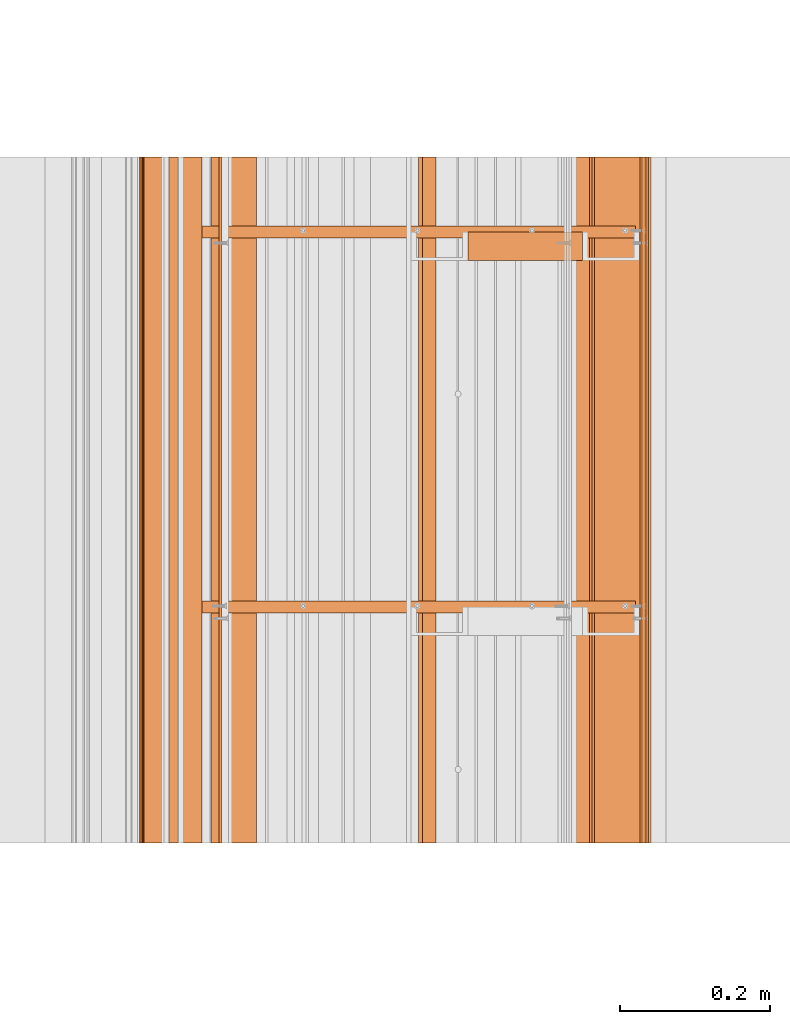
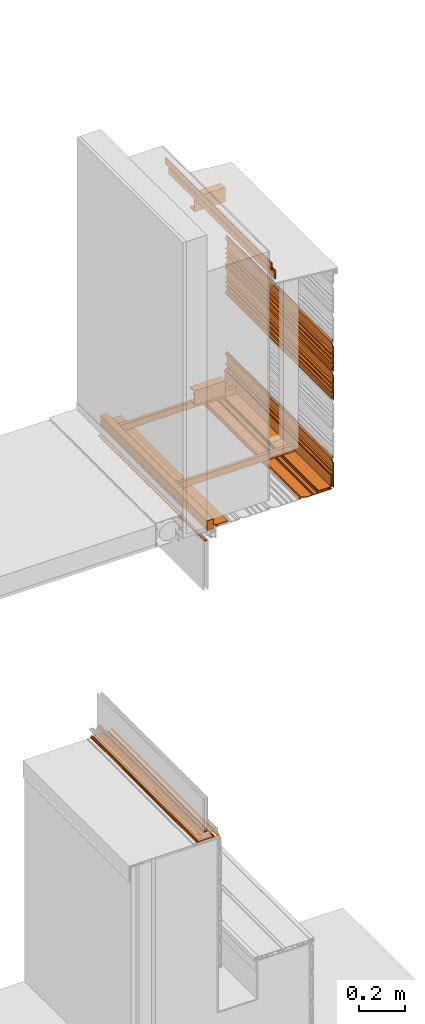
# One storey, part 6 of 36: 17 proxies.
"""IFC2X3 building model written with IfcOpenShell, lengths in feet."""

from ifc_helpers import new_model, entity, si_unit, converted_unit, derived_unit, direction, frame, frame_2d, origin, origin_2d_with_axis, place, context, subcontext, project, spatial, polyline, circle_curve, parameter, trimmed, segment, composite_curve, rectangle, outline, extrude, source, transform, mapped, material, type_object, type_shapes, element, save


model = new_model("IFC2X3")

# Units and contexts
model_context = context("Model", 3, precision=0.0001, world=origin(), true_north=direction((6.12303176911189e-17, 1.0)))
body_context = subcontext(model_context, "Body", "Model", "MODEL_VIEW")
ifc_project = project(units=[converted_unit("LENGTHUNIT", "FOOT", entity("IfcRatioMeasure", 0.3048), si_unit("LENGTHUNIT", "METRE"), dimensions=[1, 0, 0, 0, 0, 0, 0]), converted_unit("AREAUNIT", "SQUARE FOOT", entity("IfcRatioMeasure", 0.09290304), si_unit("AREAUNIT", "SQUARE_METRE"), dimensions=[2, 0, 0, 0, 0, 0, 0]), converted_unit("VOLUMEUNIT", "CUBIC FOOT", entity("IfcRatioMeasure", 0.028316846592), si_unit("VOLUMEUNIT", "CUBIC_METRE"), dimensions=[3, 0, 0, 0, 0, 0, 0]), converted_unit("PLANEANGLEUNIT", "DEGREE", entity("IfcRatioMeasure", 0.0174532925199433), si_unit("PLANEANGLEUNIT", "RADIAN"), dimensions=[0, 0, 0, 0, 0, 0, 0]), si_unit("MASSUNIT", "GRAM", prefix="KILO"), derived_unit("MASSDENSITYUNIT", [(si_unit("MASSUNIT", "GRAM", prefix="KILO"), 1), (si_unit("LENGTHUNIT", "METRE"), -3)]), si_unit("TIMEUNIT", "SECOND"), si_unit("FREQUENCYUNIT", "HERTZ"), si_unit("THERMODYNAMICTEMPERATUREUNIT", "DEGREE_CELSIUS"), derived_unit("THERMALTRANSMITTANCEUNIT", [(si_unit("MASSUNIT", "GRAM", prefix="KILO"), 1), (si_unit("THERMODYNAMICTEMPERATUREUNIT", "KELVIN"), -1), (si_unit("TIMEUNIT", "SECOND"), -3)]), derived_unit("VOLUMETRICFLOWRATEUNIT", [(si_unit("LENGTHUNIT", "METRE"), 3), (si_unit("TIMEUNIT", "SECOND"), -1)]), si_unit("ELECTRICCURRENTUNIT", "AMPERE"), si_unit("ELECTRICVOLTAGEUNIT", "VOLT"), si_unit("POWERUNIT", "WATT"), si_unit("FORCEUNIT", "NEWTON"), si_unit("ILLUMINANCEUNIT", "LUX"), si_unit("LUMINOUSFLUXUNIT", "LUMEN"), si_unit("LUMINOUSINTENSITYUNIT", "CANDELA"), derived_unit("USERDEFINED", [(si_unit("MASSUNIT", "GRAM", prefix="KILO"), -1), (si_unit("LENGTHUNIT", "METRE"), -2), (si_unit("TIMEUNIT", "SECOND"), 3), (si_unit("LUMINOUSFLUXUNIT", "LUMEN"), 1)]), derived_unit("LINEARVELOCITYUNIT", [(si_unit("LENGTHUNIT", "METRE"), 1), (si_unit("TIMEUNIT", "SECOND"), -1)]), si_unit("PRESSUREUNIT", "PASCAL"), derived_unit("USERDEFINED", [(si_unit("LENGTHUNIT", "METRE"), -2), (si_unit("MASSUNIT", "GRAM", prefix="KILO"), 1), (si_unit("TIMEUNIT", "SECOND"), -2)])], contexts=[model_context])

# Site, building, storey
site_placement = place(None, origin())
site = spatial("IfcSite", under=ifc_project, at=site_placement, CompositionType="ELEMENT")
building_placement = place(site_placement, origin())
building = spatial("IfcBuilding", under=site, at=building_placement, CompositionType="ELEMENT")
storey_placement = place(building_placement, origin())
storey = spatial("IfcBuildingStorey", under=building, at=storey_placement, Name="Level 1", CompositionType="ELEMENT", Elevation=0.0)

# Proxies
ifc_material_1 = material(Name="Window frame")
building_element_proxy_type_1 = type_object("IfcBuildingElementProxyType", Name="Window frame 094", PredefinedType="NOTDEFINED", material=ifc_material_1)
shared_shape_1 = source(origin(), body_context, "Body", "SweptSolid", [
    extrude(rectangle(XDim=3.0, YDim=0.0416666666666714, at=frame_2d((0.0, -7.105427357601e-15), x_axis=(1.0, 0.0))), frame((123.357415434482, -62.7284331589239, 4.52075), z_axis=(0.0, 0.0, 1.0), x_axis=(0.0, 1.0, 0.0)), (0.0, 0.0, 1.0), 0.0208333333333339),
])
type_shapes(building_element_proxy_type_1, [shared_shape_1])
proxy_1_placement = place(storey_placement, origin())
element("IfcBuildingElementProxy", 1, at=proxy_1_placement, inside=storey, type_object=building_element_proxy_type_1, material=ifc_material_1, Name="Window frame 094:Window frame 094", ObjectType="Window frame 094", context=body_context, shape_type="MappedRepresentation", body=[
    mapped(shared_shape_1, transform((0.0, 0.0, 0.0), scale=1.0)),
])
building_element_proxy_type_2 = type_object("IfcBuildingElementProxyType", Name="Window frame 095", PredefinedType="NOTDEFINED", material=ifc_material_1)
shared_shape_2 = source(origin(), body_context, "Body", "SweptSolid", [
    extrude(outline(composite_curve([segment(polyline([(-0.00744351318149761, 0.135335823128543), (-0.00744351318149761, 0.149502489795225)]), True, "CONTINUOUS"), segment(polyline([(-0.00744351318149761, 0.149502489795225), (-0.0141101798481644, 0.149502489795225)]), True, "CONTINUOUS"), segment(polyline([(-0.0141101798481644, 0.149502489795225), (-0.0141101798481644, -0.149660010204755)]), True, "CONTINUOUS"), segment(polyline([(-0.0141101798481644, -0.149660010204755), (-0.00744351318149761, -0.149660010204755)]), True, "CONTINUOUS"), segment(polyline([(-0.00744351318149761, -0.149660010204755), (-0.00744351318149761, -0.135493343538101)]), True, "CONTINUOUS"), segment(polyline([(-0.00744351318149761, -0.135493343538101), (-0.000276846514831064, -0.135493343538101)]), True, "CONTINUOUS"), segment(polyline([(-0.000276846514831064, -0.135493343538101), (-0.000276846514831064, -0.140660010204769)]), True, "CONTINUOUS"), segment(polyline([(-0.000276846514829288, -0.140660010204769), (0.0178066927118987, -0.134076601914842)]), True, "CONTINUOUS"), segment(trimmed(circle_curve(frame_2d((0.0168087855685712, -0.131335515204697), x_axis=(0.0, -1.0)), 0.00291708331506905), [parameter(20.0043036276874)], [parameter(200.000000499922)], True, "PARAMETER"), True, "CONTINUOUS"), segment(polyline([(0.0158110842911388, -0.12859435354801), (0.00647775095114334, -0.131969353550417)]), True, "CONTINUOUS"), segment(trimmed(circle_curve(frame_2d((0.00590771723513317, -0.13040319895471), x_axis=(0.0, -1.0)), 0.00166666692984399), [parameter(290.000003213652)], [parameter(20.0000019237645)], True, "PARAMETER"), False, "CONTINUOUS"), segment(polyline([(0.00434156265182217, -0.130973232704775), (-0.00744351318149761, -0.129660010204788)]), True, "CONTINUOUS"), segment(polyline([(-0.00744351318149761, -0.129660010204788), (-0.00744351318149761, -0.100826676871449)]), True, "CONTINUOUS"), segment(polyline([(-0.00744351318149761, -0.100826676871449), (-0.00744351318149761, 0.102314989795218)]), True, "CONTINUOUS"), segment(polyline([(-0.00744351318149761, 0.102314989795218), (-0.00744351318149761, 0.129502489795229)]), True, "CONTINUOUS"), segment(polyline([(-0.00744351318149761, 0.129502489795229), (0.00434156265178487, 0.130853212295236)]), True, "CONTINUOUS"), segment(trimmed(circle_curve(frame_2d((0.00590771723513317, 0.13028317854527), x_axis=(0.0, -1.0)), 0.00166666692984399), [parameter(159.938889813802)], [parameter(249.999996789979)], True, "PARAMETER"), False, "CONTINUOUS"), segment(polyline([(0.00647942099253029, 0.131848724286797), (0.0158110842425963, 0.128440999822942)]), True, "CONTINUOUS"), segment(trimmed(circle_curve(frame_2d((0.0168087855685712, 0.13118216146195), x_axis=(0.0, -1.0)), 0.00291708331506899), [parameter(339.999998588987)], [parameter(159.995696372378)], True, "PARAMETER"), True, "CONTINUOUS"), segment(polyline([(0.0178066927146974, 0.133923248179798), (-0.000276846514831064, 0.140506656461895)]), True, "CONTINUOUS"), segment(polyline([(-0.000276846514831064, 0.140506656461895), (-0.000276846514831064, 0.135335823128543)]), True, "CONTINUOUS"), segment(polyline([(-0.000276846514831064, 0.135335823128543), (-0.00744351318149761, 0.135335823128543)]), True, "CONTINUOUS")], self_intersect=False)), frame((123.357298205943, -64.2284331589239, 4.39944351318149), z_axis=(0.0, -1.0, 0.0), x_axis=(0.0, 0.0, 1.0)), (0.0, 0.0, -1.0), 3.0),
])
type_shapes(building_element_proxy_type_2, [shared_shape_2])
proxy_2_placement = place(storey_placement, origin())
element("IfcBuildingElementProxy", 2, at=proxy_2_placement, inside=storey, type_object=building_element_proxy_type_2, material=ifc_material_1, Name="Window frame 095:Window frame 095", ObjectType="Window frame 095", context=body_context, shape_type="MappedRepresentation", body=[
    mapped(shared_shape_2, transform((0.0, 0.0, 0.0), scale=1.0)),
])
ifc_material_2 = material()
building_element_proxy_type_3 = type_object("IfcBuildingElementProxyType", Name="Sealant 011", PredefinedType="NOTDEFINED", material=ifc_material_2)
shared_shape_3 = source(origin(), body_context, "Body", "SweptSolid", [
    extrude(outline(composite_curve([segment(polyline([(-0.00694444444445678, -0.00347222222222202), (0.00347222222222883, -0.00347222222222202)]), True, "CONTINUOUS"), segment(polyline([(0.00347222222222883, -0.00347222222222202), (0.00347222222221374, 0.00694444444444583)]), True, "CONTINUOUS"), segment(trimmed(circle_curve(frame_2d((-0.00694444444445767, 0.00694444444444583), x_axis=(-1.0, 0.0)), 0.0104166666666667), [parameter(90.0000000000001)], [parameter(179.999999999995)], True, "PARAMETER"), False, "CONTINUOUS")], self_intersect=False)), frame((123.561412114598, -64.2284331589239, 4.39917691716974), z_axis=(0.0, 1.0, 0.0), x_axis=(-1.0, 0.0, 0.0)), (0.0, 0.0, 1.0), 3.0),
])
type_shapes(building_element_proxy_type_3, [shared_shape_3])
proxy_3_placement = place(storey_placement, origin())
element("IfcBuildingElementProxy", 3, at=proxy_3_placement, inside=storey, type_object=building_element_proxy_type_3, material=ifc_material_2, Name="Sealant 011:Sealant 011", ObjectType="Sealant 011", context=body_context, shape_type="MappedRepresentation", body=[
    mapped(shared_shape_3, transform((0.0, 0.0, 0.0), scale=1.0)),
])
building_element_proxy_type_4 = type_object("IfcBuildingElementProxyType", Name="Window frame part 097", PredefinedType="NOTDEFINED", material=ifc_material_1)
shared_shape_4 = source(origin(), body_context, "Body", "SweptSolid", [
    extrude(rectangle(XDim=3.0, YDim=0.0416666666666572, at=origin_2d_with_axis()), frame((123.359415433694, -62.7284331589239, 9.53125000001312), z_axis=(0.0, 0.0, 1.0), x_axis=(0.0, 1.0, 0.0)), (0.0, 0.0, 1.0), 0.0208333333333321),
])
type_shapes(building_element_proxy_type_4, [shared_shape_4])
proxy_4_placement = place(storey_placement, origin())
element("IfcBuildingElementProxy", 4, at=proxy_4_placement, inside=storey, type_object=building_element_proxy_type_4, material=ifc_material_1, Name="Window frame part 097:Window frame part 097", ObjectType="Window frame part 097", context=body_context, shape_type="MappedRepresentation", body=[
    mapped(shared_shape_4, transform((0.0, 0.0, 0.0), scale=1.0)),
])
ifc_material_3 = material(Name="_EXISTING CAST-IN-PLACE CONCRETE")
building_element_proxy_type_5 = type_object("IfcBuildingElementProxyType", Name="starter strip 018", PredefinedType="NOTDEFINED", material=ifc_material_3)
shared_shape_5 = source(origin(), body_context, "Body", "SweptSolid", [
    extrude(outline(polyline([(-0.0613594857283317, -0.0154211442749244), (-0.0251609571194251, -0.0154211442749244), (-0.0251609571194251, -0.00592609112533005), (-0.0504897785761216, -0.00592609112533005), (-0.0504897785761216, 0.0053841388615421), (0.137010221423907, 0.0053841388615421), (0.137010221423907, 0.0159630965387141), (-0.0613594857283317, 0.0159630965387141), (-0.0613594857283317, -0.0154211442749244)])), frame((125.338156285059, -64.2284331589239, 9.74081747039039), z_axis=(0.0, 1.0, 0.0), x_axis=(-1.0, 0.0, 0.0)), (0.0, 0.0, 1.0), 3.0),
])
type_shapes(building_element_proxy_type_5, [shared_shape_5])
proxy_5_placement = place(storey_placement, origin())
element("IfcBuildingElementProxy", 5, at=proxy_5_placement, inside=storey, type_object=building_element_proxy_type_5, material=ifc_material_3, Name="starter strip 018:starter strip 018", ObjectType="starter strip 018", context=body_context, shape_type="MappedRepresentation", body=[
    mapped(shared_shape_5, transform((0.0, 0.0, 0.0), scale=1.0)),
])
building_element_proxy_type_6 = type_object("IfcBuildingElementProxyType", Name="Flashing 005", PredefinedType="NOTDEFINED", material=ifc_material_3)
shared_shape_6 = source(origin(), body_context, "Body", "SweptSolid", [
    extrude(outline(polyline([(0.013667551313393, -0.0378577431199574), (0.159773698392035, -0.0378577431199574), (0.159773698392035, -0.0199414287766899), (0.0215603079392768, -0.0199414287766899), (-0.0313095939307999, 0.0378577431393126), (-0.14213165577463, 0.0378577431393126), (-0.14213165577463, 0.0199414287572921), (-0.0392023505566836, 0.0199414287572921), (0.013667551313393, -0.0378577431199574)])), frame((124.468231916026, -64.2284331589239, 13.807758480938), z_axis=(0.0, 1.0, 0.0), x_axis=(0.0, 0.0, -1.0)), (0.0, 0.0, 1.0), 3.0),
])
type_shapes(building_element_proxy_type_6, [shared_shape_6])
proxy_6_placement = place(storey_placement, origin())
element("IfcBuildingElementProxy", 6, at=proxy_6_placement, inside=storey, type_object=building_element_proxy_type_6, material=ifc_material_3, Name="Flashing 005:Flashing 005", ObjectType="Flashing 005", context=body_context, shape_type="MappedRepresentation", body=[
    mapped(shared_shape_6, transform((0.0, 0.0, 0.0), scale=1.0)),
])
building_element_proxy_type_7 = type_object("IfcBuildingElementProxyType", Name="starter strip 019", PredefinedType="NOTDEFINED", material=ifc_material_3)
shared_shape_7 = source(origin(), body_context, "Body", "SweptSolid", [
    extrude(outline(polyline([(-0.0504897786253338, 0.00592609117455645), (-0.0251609571030116, 0.00592609117455645), (-0.0251609571030116, 0.015421144422568), (-0.0613594856463209, 0.015421144422568), (-0.0613594856463209, -0.0159630966207356), (0.137010221374666, -0.0159630966207356), (0.137010221374666, -0.00538413897637824), (-0.0504897786253338, -0.00538413897637824), (-0.0504897786253338, 0.00592609117455645)])), frame((123.583477418704, -64.2284331589239, 9.7408174703082), z_axis=(0.0, 1.0, 0.0), x_axis=(1.0, 0.0, 0.0)), (0.0, 0.0, 1.0), 3.0),
])
type_shapes(building_element_proxy_type_7, [shared_shape_7])
proxy_7_placement = place(storey_placement, origin())
element("IfcBuildingElementProxy", 7, at=proxy_7_placement, inside=storey, type_object=building_element_proxy_type_7, material=ifc_material_3, Name="starter strip 019:starter strip 019", ObjectType="starter strip 019", context=body_context, shape_type="MappedRepresentation", body=[
    mapped(shared_shape_7, transform((0.0, 0.0, 0.0), scale=1.0)),
])
building_element_proxy_type_8 = type_object("IfcBuildingElementProxyType", Name="Metal support for window frame003", PredefinedType="NOTDEFINED", material=ifc_material_3)
shared_shape_8 = source(origin(), body_context, "Body", "SweptSolid", [
    extrude(rectangle(XDim=3.0, YDim=0.107278015091865, at=frame_2d((0.0, 7.105427357601e-15), x_axis=(1.0, 0.0))), frame((123.430507377612, -62.7284331589239, 9.70833333333333), z_axis=(0.0, 0.0, 1.0), x_axis=(0.0, 1.0, 0.0)), (0.0, 0.0, 1.0), 0.166666666666668),
])
type_shapes(building_element_proxy_type_8, [shared_shape_8])
proxy_8_placement = place(storey_placement, origin())
element("IfcBuildingElementProxy", 8, at=proxy_8_placement, inside=storey, type_object=building_element_proxy_type_8, material=ifc_material_3, ObjectType="Metal support for window frame003", context=body_context, shape_type="MappedRepresentation", body=[
    mapped(shared_shape_8, transform((0.0, 0.0, 0.0), scale=1.0)),
])
building_element_proxy_type_9 = type_object("IfcBuildingElementProxyType", Name="panel 058", PredefinedType="NOTDEFINED", material=ifc_material_3)
shared_shape_9 = source(origin(), body_context, "Body", "SweptSolid", [
    extrude(outline(polyline([(-0.145680147068468, -0.0220175316852362), (0.291819852931525, -0.0220175316852362), (0.291819852931525, -0.0116008650185648), (0.237132352931535, -0.0116008650185648), (0.237132352931535, 0.00451787028327999), (0.257965686264864, 0.00451787028327999), (0.257965686264864, 0.0173047730391858), (0.22671568626486, 0.0173047730391858), (0.22671568626486, -0.0116008650185648), (0.143382352931521, -0.0116008650185648), (0.143382352931521, 0.0196491349814352), (0.132965686264869, 0.0196491349814352), (0.132965686264869, -0.0116008650185648), (0.060049019598182, -0.0116008650185648), (0.060049019598182, 0.0196491349814352), (0.0496323529315319, 0.0196491349814352), (0.0496323529315319, -0.0116008650185648), (-0.0232843137351324, -0.0116008650185648), (-0.0232843137351324, 0.0196491349814352), (-0.0337009804018074, 0.0196491349814352), (-0.0337009804018074, -0.0116008650185648), (-0.135263480401816, -0.0116008650185648), (-0.135263480401816, -0.00118419835187922), (-0.180710665113098, -0.00118419835187922), (-0.18994960080863, 0.0186287630982349), (-0.215994026661651, 0.0186287630982349), (-0.225232962029096, -0.00118419835187922), (-0.249846813735136, -0.00118419835187922), (-0.249846813735136, -0.0116008650185648), (-0.218596813735132, -0.0116008650185648), (-0.210299318000233, 0.00619317215335968), (-0.195644309470049, 0.00619317215335968), (-0.18734681373515, -0.0116008650185648), (-0.145680147068468, -0.0116008650185648), (-0.145680147068468, -0.0220175316852362)])), frame((125.424633043827, -64.2284331589239, 10.021009163627), z_axis=(0.0, 1.0, 0.0), x_axis=(0.0, 0.0, -1.0)), (0.0, 0.0, 1.0), 3.0),
])
type_shapes(building_element_proxy_type_9, [shared_shape_9])
proxy_9_placement = place(storey_placement, origin())
element("IfcBuildingElementProxy", 9, at=proxy_9_placement, inside=storey, type_object=building_element_proxy_type_9, material=ifc_material_3, Name="panel 058:panel 058", ObjectType="panel 058", context=body_context, shape_type="MappedRepresentation", body=[
    mapped(shared_shape_9, transform((0.0, 0.0, 0.0), scale=1.0)),
])
building_element_proxy_type_10 = type_object("IfcBuildingElementProxyType", Name="panel 059", PredefinedType="NOTDEFINED", material=ifc_material_3)
shared_shape_10 = source(origin(), body_context, "Body", "SweptSolid", [
    extrude(outline(polyline([(-0.145680147068472, -0.0220175316852362), (0.291819852931523, -0.0220175316852362), (0.291819852931523, -0.0116008650185648), (0.237132352931534, -0.0116008650185648), (0.237132352931534, 0.00451787028327999), (0.25796568626486, 0.00451787028327999), (0.25796568626486, 0.0173047730391858), (0.226715686264857, 0.0173047730391858), (0.226715686264857, -0.0116008650185648), (0.143382352931518, -0.0116008650185648), (0.143382352931518, 0.0196491349814352), (0.132965686264866, 0.0196491349814352), (0.132965686264866, -0.0116008650185648), (0.0600490195981802, -0.0116008650185648), (0.0600490195981802, 0.0196491349814352), (0.0496323529315283, 0.0196491349814352), (0.0496323529315283, -0.0116008650185648), (-0.0232843137351342, -0.0116008650185648), (-0.0232843137351342, 0.0196491349814352), (-0.0337009804018109, 0.0196491349814352), (-0.0337009804018109, -0.0116008650185648), (-0.13526348040182, -0.0116008650185648), (-0.13526348040182, -0.00118419835187922), (-0.180710665113102, -0.00118419835187922), (-0.189949600808633, 0.0186287630982349), (-0.215994026661654, 0.0186287630982349), (-0.2252329620291, -0.00118419835187922), (-0.24984681373514, -0.00118419835187922), (-0.24984681373514, -0.0116008650185648), (-0.218596813735134, -0.0116008650185648), (-0.210299318000237, 0.00619317215335968), (-0.195644309470051, 0.00619317215335968), (-0.187346813735154, -0.0116008650185648), (-0.145680147068472, -0.0116008650185648), (-0.145680147068472, -0.0220175316852362)])), frame((125.424633043827, -64.2284331589239, 11.521009163627), z_axis=(0.0, 1.0, 0.0), x_axis=(0.0, 0.0, -1.0)), (0.0, 0.0, 1.0), 3.0),
])
type_shapes(building_element_proxy_type_10, [shared_shape_10])
proxy_10_placement = place(storey_placement, origin())
element("IfcBuildingElementProxy", 10, at=proxy_10_placement, inside=storey, type_object=building_element_proxy_type_10, material=ifc_material_3, Name="panel 059:panel 059", ObjectType="panel 059", context=body_context, shape_type="MappedRepresentation", body=[
    mapped(shared_shape_10, transform((0.0, 0.0, 0.0), scale=1.0)),
])
building_element_proxy_type_11 = type_object("IfcBuildingElementProxyType", Name="starter strip 020", PredefinedType="NOTDEFINED", material=ifc_material_3)
shared_shape_11 = source(origin(), body_context, "Body", "SweptSolid", [
    extrude(outline(polyline([(-0.050489778625332, 0.00592609117455822), (-0.0251609571030116, 0.00592609117455822), (-0.0251609571030116, 0.0154211444225609), (-0.0613594856463298, 0.0154211444225609), (-0.0613594856463298, -0.0159630966207374), (0.137010221374673, -0.0159630966207374), (0.137010221374673, -0.00538413897638179), (-0.050489778625332, -0.00538413897638179), (-0.050489778625332, 0.00592609117455822)])), frame((125.415604431089, -64.2284331589239, 9.81008004634182), z_axis=(0.0, 1.0, 0.0), x_axis=(0.0, 0.0, 1.0)), (0.0, 0.0, 1.0), 3.0),
])
type_shapes(building_element_proxy_type_11, [shared_shape_11])
proxy_11_placement = place(storey_placement, origin())
element("IfcBuildingElementProxy", 11, at=proxy_11_placement, inside=storey, type_object=building_element_proxy_type_11, material=ifc_material_3, Name="starter strip 020:starter strip 020", ObjectType="starter strip 020", context=body_context, shape_type="MappedRepresentation", body=[
    mapped(shared_shape_11, transform((0.0, 0.0, 0.0), scale=1.0)),
])
building_element_proxy_type_12 = type_object("IfcBuildingElementProxyType", Name="panel 060", PredefinedType="NOTDEFINED", material=ifc_material_3)
shared_shape_12 = source(origin(), body_context, "Body", "SweptSolid", [
    extrude(outline(polyline([(0.0116008650030874, -0.29181985294116), (0.0220175316697411, -0.29181985294116), (0.0220175316697411, 0.145680147058869), (0.0116008650030874, 0.145680147058869), (0.0116008650030874, 0.187346813725526), (-0.00619317207042336, 0.195644309526045), (-0.00619317207042336, 0.210299317925006), (0.0116008650030874, 0.218596813725526), (0.0116008650030874, 0.24984681372554), (0.0011841983364107, 0.24984681372554), (0.0011841983364107, 0.22523296228195), (-0.0186287629496711, 0.215994026619228), (-0.0186287629496711, 0.189949600831824), (0.0011841983364107, 0.180710665169102), (0.0011841983364107, 0.135263480392183), (0.0116008650030874, 0.135263480392183), (0.0116008650030874, 0.0337009803921688), (-0.0196491349969179, 0.0337009803921688), (-0.0196491349969179, 0.0232843137255401), (0.0116008650030874, 0.0232843137255401), (0.0116008650030874, -0.0496323529411313), (-0.0196491349969179, -0.0496323529411313), (-0.0196491349969179, -0.0600490196078169), (0.0116008650030874, -0.0600490196078169), (0.0116008650030874, -0.132965686274474), (-0.0196491349969179, -0.132965686274474), (-0.0196491349969179, -0.143382352941146), (0.0116008650030874, -0.143382352941146), (0.0116008650030874, -0.226715686274488), (-0.0173047731202853, -0.226715686274488), (-0.0173047731202853, -0.257965686274474), (-0.00451787023313521, -0.257965686274474), (-0.00451787023313521, -0.237132352941131), (0.0116008650030874, -0.237132352941131), (0.0116008650030874, -0.29181985294116)])), frame((125.128789055904, -64.2284331589239, 9.73037350903193), z_axis=(0.0, 1.0, 0.0), x_axis=(0.0, 0.0, -1.0)), (0.0, 0.0, 1.0), 3.0),
])
type_shapes(building_element_proxy_type_12, [shared_shape_12])
proxy_12_placement = place(storey_placement, origin())
element("IfcBuildingElementProxy", 12, at=proxy_12_placement, inside=storey, type_object=building_element_proxy_type_12, material=ifc_material_3, Name="panel 060:panel 060", ObjectType="panel 060", context=body_context, shape_type="MappedRepresentation", body=[
    mapped(shared_shape_12, transform((0.0, 0.0, 0.0), scale=1.0)),
])
building_element_proxy_type_13 = type_object("IfcBuildingElementProxyType", Name="panel 061", PredefinedType="NOTDEFINED", material=ifc_material_3)
shared_shape_13 = source(origin(), body_context, "Body", "SweptSolid", [
    extrude(outline(polyline([(-0.145680147068472, -0.0220175316852362), (0.291819852931523, -0.0220175316852362), (0.291819852931523, -0.0116008650185648), (0.237132352931532, -0.0116008650185648), (0.237132352931532, 0.00451787028327999), (0.25796568626486, 0.00451787028327999), (0.25796568626486, 0.0173047730391858), (0.226715686264857, 0.0173047730391858), (0.226715686264857, -0.0116008650185648), (0.143382352931518, -0.0116008650185648), (0.143382352931518, 0.0196491349814352), (0.132965686264866, 0.0196491349814352), (0.132965686264866, -0.0116008650185648), (0.0600490195981784, -0.0116008650185648), (0.0600490195981784, 0.0196491349814352), (0.0496323529315283, 0.0196491349814352), (0.0496323529315283, -0.0116008650185648), (-0.0232843137351342, -0.0116008650185648), (-0.0232843137351342, 0.0196491349814352), (-0.0337009804018109, 0.0196491349814352), (-0.0337009804018109, -0.0116008650185648), (-0.13526348040182, -0.0116008650185648), (-0.13526348040182, -0.00118419835187922), (-0.180710665113102, -0.00118419835187922), (-0.189949600808633, 0.0186287630982349), (-0.215994026661654, 0.0186287630982349), (-0.2252329620291, -0.00118419835187922), (-0.24984681373514, -0.00118419835187922), (-0.24984681373514, -0.0116008650185648), (-0.218596813735134, -0.0116008650185648), (-0.210299318000237, 0.00619317215335968), (-0.195644309470053, 0.00619317215335968), (-0.187346813735154, -0.0116008650185648), (-0.145680147068472, -0.0116008650185648), (-0.145680147068472, -0.0220175316852362)])), frame((125.424633043827, -64.2284331589239, 12.021009163627), z_axis=(0.0, 1.0, 0.0), x_axis=(0.0, 0.0, -1.0)), (0.0, 0.0, 1.0), 3.0),
])
type_shapes(building_element_proxy_type_13, [shared_shape_13])
proxy_13_placement = place(storey_placement, origin())
element("IfcBuildingElementProxy", 13, at=proxy_13_placement, inside=storey, type_object=building_element_proxy_type_13, material=ifc_material_3, Name="panel 061:panel 061", ObjectType="panel 061", context=body_context, shape_type="MappedRepresentation", body=[
    mapped(shared_shape_13, transform((0.0, 0.0, 0.0), scale=1.0)),
])
building_element_proxy_type_14 = type_object("IfcBuildingElementProxyType", Name="Stud 007", PredefinedType="NOTDEFINED", material=ifc_material_3)
shared_shape_14 = source(origin(), body_context, "Body", "SweptSolid", [
    extrude(outline(polyline([(-0.0286458333333286, -0.0572916666666679), (0.0234375000000071, -0.0572916666666679), (0.0234375000000071, -0.046875), (-0.0182291666666572, -0.046875), (-0.0182291666666572, 0.046875), (0.0234375000000071, 0.046875), (0.0234375000000071, 0.0572916666666661), (-0.0286458333333286, 0.0572916666666661), (-0.0286458333333286, -0.0572916666666679)])), frame((123.484146385157, -63.1943329292651, 9.81770833333333), z_axis=(1.0, 0.0, 0.0), x_axis=(0.0, 1.0, 0.0)), (0.0, 0.0, 1.0), 1.89583333333333),
])
type_shapes(building_element_proxy_type_14, [shared_shape_14])
proxy_14_placement = place(storey_placement, origin())
element("IfcBuildingElementProxy", 14, at=proxy_14_placement, inside=storey, type_object=building_element_proxy_type_14, material=ifc_material_3, Name="Stud 007:Stud 007", ObjectType="Stud 007", context=body_context, shape_type="MappedRepresentation", body=[
    mapped(shared_shape_14, transform((0.0, 0.0, 0.0), scale=1.0)),
])
building_element_proxy_type_15 = type_object("IfcBuildingElementProxyType", Name="Stud 008", PredefinedType="NOTDEFINED", material=ifc_material_3)
shared_shape_15 = source(origin(), body_context, "Body", "SweptSolid", [
    extrude(outline(polyline([(-0.0286458333333357, -0.0572916666666679), (0.0234375000000071, -0.0572916666666679), (0.0234375000000071, -0.046875), (-0.0182291666666572, -0.046875), (-0.0182291666666572, 0.046875), (0.0234375000000071, 0.046875), (0.0234375000000071, 0.0572916666666661), (-0.0286458333333357, 0.0572916666666661), (-0.0286458333333357, -0.0572916666666679)])), frame((123.484146385157, -61.5539129817585, 9.81770833333333), z_axis=(1.0, 0.0, 0.0), x_axis=(0.0, 1.0, 0.0)), (0.0, 0.0, 1.0), 1.89583333333333),
])
type_shapes(building_element_proxy_type_15, [shared_shape_15])
proxy_15_placement = place(storey_placement, origin())
element("IfcBuildingElementProxy", 15, at=proxy_15_placement, inside=storey, type_object=building_element_proxy_type_15, material=ifc_material_3, Name="Stud 008:Stud 008", ObjectType="Stud 008", context=body_context, shape_type="MappedRepresentation", body=[
    mapped(shared_shape_15, transform((0.0, 0.0, 0.0), scale=1.0)),
])
building_element_proxy_type_16 = type_object("IfcBuildingElementProxyType", Name="Metal stud 026", PredefinedType="NOTDEFINED", material=ifc_material_3)
shared_shape_16 = source(origin(), body_context, "Body", "SweptSolid", [
    extrude(outline(polyline([(-0.0661909448818889, -0.125), (0.0588090551181111, -0.125), (0.0588090551181111, -0.100393700787402), (-0.0514271653543332, -0.100393700787402), (-0.0514271653543332, 0.100393700787404), (0.0588090551181111, 0.100393700787404), (0.0588090551181111, 0.125000000000002), (-0.0661909448818889, 0.125000000000002), (-0.0661909448818889, -0.125)])), frame((124.647701703619, -61.6153262035433, 10.0), z_axis=(1.0, 0.0, 0.0), x_axis=(0.0, 1.0, 0.0)), (0.0, 0.0, 1.0), 0.5),
])
type_shapes(building_element_proxy_type_16, [shared_shape_16])
proxy_16_placement = place(storey_placement, origin())
element("IfcBuildingElementProxy", 16, at=proxy_16_placement, inside=storey, type_object=building_element_proxy_type_16, material=ifc_material_3, Name="Metal stud 026:Metal stud 026", ObjectType="Metal stud 026", context=body_context, shape_type="MappedRepresentation", body=[
    mapped(shared_shape_16, transform((0.0, 0.0, 0.0), scale=1.0)),
])
building_element_proxy_type_17 = type_object("IfcBuildingElementProxyType", Name="Metal stud 027", PredefinedType="NOTDEFINED", material=ifc_material_3)
shared_shape_17 = source(origin(), body_context, "Body", "SweptSolid", [
    extrude(outline(polyline([(-0.0661909448818889, -0.125), (0.0588090551181111, -0.125), (0.0588090551181111, -0.1003937007874), (-0.0514271653543332, -0.1003937007874), (-0.0514271653543332, 0.1003937007874), (0.0588090551181111, 0.1003937007874), (0.0588090551181111, 0.125), (-0.0661909448818889, 0.125), (-0.0661909448818889, -0.125)])), frame((124.647701703619, -61.6153262035433, 13.3333333333333), z_axis=(1.0, 0.0, 0.0), x_axis=(0.0, 1.0, 0.0)), (0.0, 0.0, 1.0), 0.5),
])
type_shapes(building_element_proxy_type_17, [shared_shape_17])
proxy_17_placement = place(storey_placement, origin())
element("IfcBuildingElementProxy", 17, at=proxy_17_placement, inside=storey, type_object=building_element_proxy_type_17, material=ifc_material_3, Name="Metal stud 027:Metal stud 027", ObjectType="Metal stud 027", context=body_context, shape_type="MappedRepresentation", body=[
    mapped(shared_shape_17, transform((0.0, 0.0, 0.0), scale=1.0)),
])

save(model, "model.ifc")
